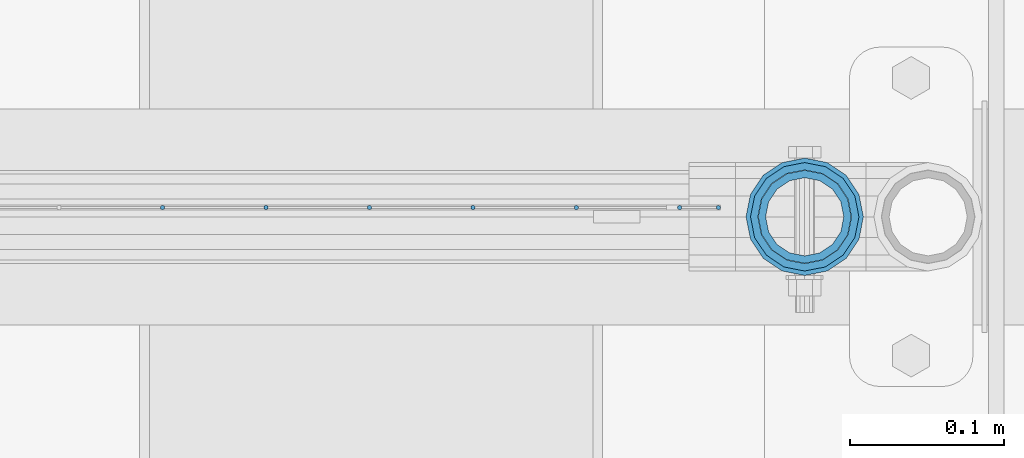
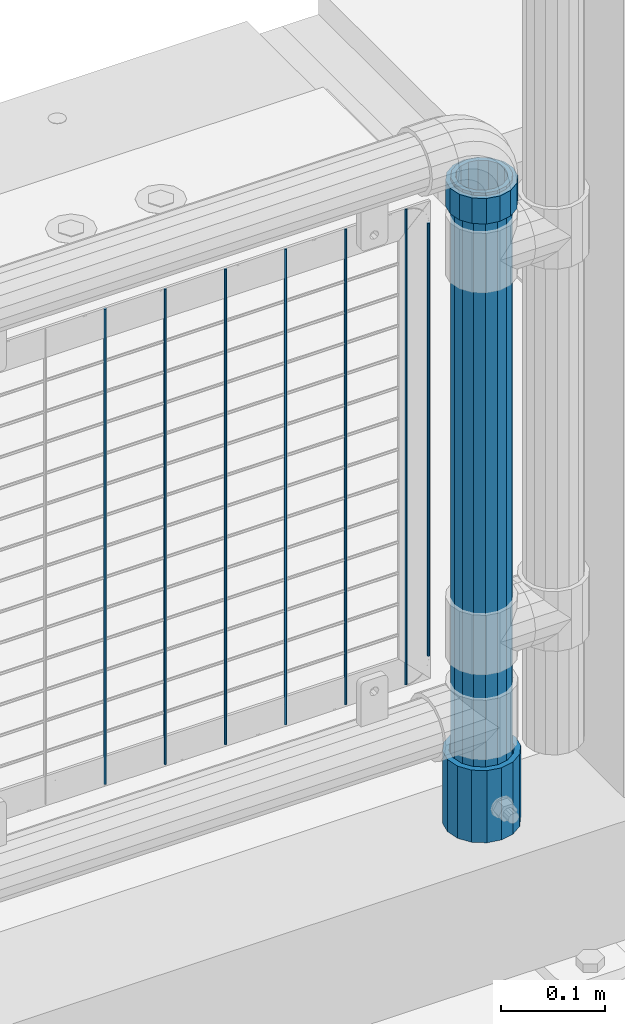
# One storey, part 93 of 219: 10 columns.
"""IFC2X3 building model written with IfcOpenShell, lengths in millimetres."""

from ifc_helpers import new_model, si_unit, frame, origin_with_axes, place, context, subcontext, project, spatial, faceted_brep, material, type_object, element, save


model = new_model("IFC2X3")

# Units and contexts
model_context = context("Model", 3, precision=1e-05, world=origin_with_axes())
body_context = subcontext(model_context, "Body", "Model", "MODEL_VIEW")
ifc_project = project(units=[si_unit("LENGTHUNIT", "METRE", prefix="MILLI"), si_unit("AREAUNIT", "SQUARE_METRE"), si_unit("VOLUMEUNIT", "CUBIC_METRE"), si_unit("MASSUNIT", "GRAM", prefix="KILO"), si_unit("TIMEUNIT", "SECOND"), si_unit("PLANEANGLEUNIT", "RADIAN"), si_unit("SOLIDANGLEUNIT", "STERADIAN"), si_unit("THERMODYNAMICTEMPERATUREUNIT", "DEGREE_CELSIUS"), si_unit("LUMINOUSINTENSITYUNIT", "LUMEN")], contexts=[model_context])

# Site, building, storey
site_placement = place(None, origin_with_axes())
site = spatial("IfcSite", under=ifc_project, at=site_placement, CompositionType="ELEMENT")
building_placement = place(site_placement, origin_with_axes())
building = spatial("IfcBuilding", under=site, at=building_placement, Name="Standard", CompositionType="ELEMENT")
storey_placement = place(building_placement, origin_with_axes())
storey = spatial("IfcBuildingStorey", under=building, at=storey_placement, Name="Undefined", CompositionType="ELEMENT", Elevation=0.0)

# Columns
ifc_material_1 = material(Name="Misc_Undefined")
column_type_1 = type_object("IfcColumnType", PredefinedType="NOTDEFINED")
column_1_placement = place(storey_placement, frame((13431.0, 31664.5, 894.85), z_axis=(1.0, 0.0, 0.0), x_axis=(0.0, 0.0, 1.0)))
element("IfcColumn", 1, at=column_1_placement, inside=storey, type_object=column_type_1, material=ifc_material_1, context=body_context, shape_type="Brep", body=[
    faceted_brep([(0.0, -30.3499999999985, 0.0), (0.0, -28.0397438117179, 11.6144421722802), (30.0, -28.0397438117179, 11.6144421722805), (30.0, -30.3499999999985, 0.0), (0.0, -21.46069080901, 21.4606908090118), (30.0, -21.46069080901, 21.4606908090117), (0.0, -11.614442172282, 28.0397438117179), (30.0, -11.614442172282, 28.0397438117176), (0.0, 0.0, 30.3500000000004), (30.0, 0.0, 30.35), (0.0, 11.614442172282, 28.0397438117179), (30.0, 11.614442172282, 28.0397438117176), (0.0, 21.46069080901, 21.4606908090118), (30.0, 21.46069080901, 21.4606908090117), (0.0, 28.0397438117179, 11.6144421722802), (30.0, 28.0397438117179, 11.6144421722805), (0.0, 30.3499999999985, 0.0), (30.0, 30.3499999999985, 0.0), (0.0, 28.0397438117179, -11.6144421722802), (30.0, 28.0397438117179, -11.6144421722805), (0.0, 21.46069080901, -21.4606908090118), (30.0, 21.46069080901, -21.4606908090117), (0.0, 11.614442172282, -28.0397438117179), (30.0, 11.614442172282, -28.0397438117176), (0.0, 0.0, -30.3500000000004), (30.0, 0.0, -30.35), (0.0, -11.614442172282, -28.0397438117179), (30.0, -11.614442172282, -28.0397438117176), (0.0, -21.46069080901, -21.4606908090118), (30.0, -21.46069080901, -21.4606908090117), (0.0, -28.0397438117179, -11.6144421722802), (30.0, -28.0397438117179, -11.6144421722805), (0.0, -35.1500000000015, 0.0), (0.0, -32.4743655677703, -13.4513226476338), (30.0, -32.4743655677703, -13.4513226476329), (30.0, -35.1500000000015, 0.0), (0.0, -24.8548033587067, -24.8548033587067), (30.0, -24.8548033587067, -24.8548033587072), (0.0, -13.4513226476338, -32.4743655677721), (30.0, -13.4513226476338, -32.4743655677718), (0.0, 0.0, -35.1500000000015), (30.0, 0.0, -35.15), (0.0, 13.4513226476338, -32.4743655677721), (30.0, 13.4513226476338, -32.4743655677718), (0.0, 24.8548033587067, -24.8548033587067), (30.0, 24.8548033587067, -24.8548033587072), (0.0, 32.4743655677703, -13.4513226476338), (30.0, 32.4743655677703, -13.4513226476329), (0.0, 35.1500000000015, 0.0), (30.0, 35.1500000000015, 0.0), (0.0, 32.4743655677703, 13.4513226476338), (30.0, 32.4743655677703, 13.4513226476329), (0.0, 24.8548033587067, 24.8548033587067), (30.0, 24.8548033587067, 24.8548033587072), (0.0, 13.4513226476338, 32.4743655677721), (30.0, 13.4513226476338, 32.4743655677718), (0.0, 0.0, 35.1500000000015), (30.0, 0.0, 35.15), (0.0, -13.4513226476338, 32.4743655677721), (30.0, -13.4513226476338, 32.4743655677718), (0.0, -24.8548033587067, 24.8548033587067), (30.0, -24.8548033587067, 24.8548033587072), (0.0, -32.4743655677703, 13.4513226476338), (30.0, -32.4743655677703, 13.4513226476329)], [[[0, 1, 2, 3]], [[1, 4, 5, 2]], [[4, 6, 7, 5]], [[6, 8, 9, 7]], [[8, 10, 11, 9]], [[10, 12, 13, 11]], [[12, 14, 15, 13]], [[14, 16, 17, 15]], [[16, 18, 19, 17]], [[18, 20, 21, 19]], [[20, 22, 23, 21]], [[22, 24, 25, 23]], [[24, 26, 27, 25]], [[26, 28, 29, 27]], [[28, 30, 31, 29]], [[30, 0, 3, 31]], [[32, 33, 34, 35]], [[33, 36, 37, 34]], [[36, 38, 39, 37]], [[38, 40, 41, 39]], [[40, 42, 43, 41]], [[42, 44, 45, 43]], [[44, 46, 47, 45]], [[46, 48, 49, 47]], [[48, 50, 51, 49]], [[50, 52, 53, 51]], [[52, 54, 55, 53]], [[54, 56, 57, 55]], [[56, 58, 59, 57]], [[58, 60, 61, 59]], [[60, 62, 63, 61]], [[62, 32, 35, 63]], [[37, 39, 41, 43, 45, 47, 49, 51, 53, 55, 57, 59, 61, 63, 35, 34], [5, 7, 9, 11, 13, 15, 17, 19, 21, 23, 25, 27, 29, 31, 3, 2]], [[62, 60, 58, 56, 54, 52, 50, 48, 46, 44, 42, 40, 38, 36, 33, 32], [30, 28, 26, 24, 22, 20, 18, 16, 14, 12, 10, 8, 6, 4, 1, 0]]]),
])
ifc_material_2 = material()
column_type_2 = type_object("IfcColumnType", PredefinedType="NOTDEFINED")
column_2_placement = place(storey_placement, frame((13431.0, 31664.5, 168.019999999998), z_axis=(-1.0, 0.0, 0.0), x_axis=(0.0, 0.0, 1.0)))
element("IfcColumn", 2, at=column_2_placement, inside=storey, type_object=column_type_2, material=ifc_material_2, context=body_context, shape_type="Brep", body=[
    faceted_brep([(0.0, -25.3499999999985, 0.0), (0.0, -23.4203461491597, 9.70102501045585), (760.0, -23.4203461491597, 9.70102501045585), (760.0, -25.3499999999985, 0.0), (0.0, -17.9251569030785, 17.9251569030785), (760.0, -17.9251569030785, 17.9251569030785), (0.0, -9.70102501045403, 23.4203461491616), (760.0, -9.70102501045403, 23.4203461491616), (0.0, 0.0, 25.3500000000004), (760.0, 0.0, 25.3500000000004), (0.0, 9.70102501045403, 23.4203461491616), (760.0, 9.70102501045403, 23.4203461491616), (0.0, 17.9251569030785, 17.9251569030785), (760.0, 17.9251569030785, 17.9251569030785), (0.0, 23.4203461491597, 9.70102501045585), (760.0, 23.4203461491597, 9.70102501045585), (0.0, 25.3499999999985, 0.0), (760.0, 25.3499999999985, 0.0), (0.0, 23.4203461491597, -9.70102501045585), (760.0, 23.4203461491597, -9.70102501045585), (0.0, 17.9251569030785, -17.9251569030785), (760.0, 17.9251569030785, -17.9251569030785), (0.0, 9.70102501045403, -23.4203461491616), (760.0, 9.70102501045403, -23.4203461491616), (0.0, 0.0, -25.3500000000004), (760.0, 0.0, -25.3500000000004), (0.0, -9.70102501045403, -23.4203461491616), (760.0, -9.70102501045403, -23.4203461491616), (0.0, -17.9251569030785, -17.9251569030785), (760.0, -17.9251569030785, -17.9251569030785), (0.0, -23.4203461491597, -9.70102501045585), (760.0, -23.4203461491597, -9.70102501045585), (0.0, -30.1500000000015, 0.0), (0.0, -27.8549679052157, -11.5379054858076), (760.0, -27.8549679052157, -11.5379054858076), (760.0, -30.1500000000015, 0.0), (0.0, -21.3192694527752, -21.3192694527752), (760.0, -21.3192694527752, -21.3192694527752), (0.0, -11.5379054858058, -27.8549679052157), (760.0, -11.5379054858058, -27.8549679052157), (0.0, 0.0, -30.1499999999996), (760.0, 0.0, -30.1499999999996), (0.0, 11.5379054858058, -27.8549679052157), (760.0, 11.5379054858058, -27.8549679052157), (0.0, 21.3192694527752, -21.3192694527752), (760.0, 21.3192694527752, -21.3192694527752), (0.0, 27.8549679052157, -11.5379054858076), (760.0, 27.8549679052157, -11.5379054858076), (0.0, 30.1500000000015, 0.0), (760.0, 30.1500000000015, 0.0), (0.0, 27.8549679052157, 11.5379054858076), (760.0, 27.8549679052157, 11.5379054858076), (0.0, 21.3192694527752, 21.3192694527752), (760.0, 21.3192694527752, 21.3192694527752), (0.0, 11.5379054858058, 27.8549679052157), (760.0, 11.5379054858058, 27.8549679052157), (0.0, 0.0, 30.1499999999996), (760.0, 0.0, 30.1499999999996), (0.0, -11.5379054858058, 27.8549679052157), (760.0, -11.5379054858058, 27.8549679052157), (0.0, -21.3192694527752, 21.3192694527752), (760.0, -21.3192694527752, 21.3192694527752), (0.0, -27.8549679052157, 11.5379054858076), (760.0, -27.8549679052157, 11.5379054858076)], [[[0, 1, 2, 3]], [[1, 4, 5, 2]], [[4, 6, 7, 5]], [[6, 8, 9, 7]], [[8, 10, 11, 9]], [[10, 12, 13, 11]], [[12, 14, 15, 13]], [[14, 16, 17, 15]], [[16, 18, 19, 17]], [[18, 20, 21, 19]], [[20, 22, 23, 21]], [[22, 24, 25, 23]], [[24, 26, 27, 25]], [[26, 28, 29, 27]], [[28, 30, 31, 29]], [[30, 0, 3, 31]], [[32, 33, 34, 35]], [[33, 36, 37, 34]], [[36, 38, 39, 37]], [[38, 40, 41, 39]], [[40, 42, 43, 41]], [[42, 44, 45, 43]], [[44, 46, 47, 45]], [[46, 48, 49, 47]], [[48, 50, 51, 49]], [[50, 52, 53, 51]], [[52, 54, 55, 53]], [[54, 56, 57, 55]], [[56, 58, 59, 57]], [[58, 60, 61, 59]], [[60, 62, 63, 61]], [[62, 32, 35, 63]], [[37, 39, 41, 43, 45, 47, 49, 51, 53, 55, 57, 59, 61, 63, 35, 34], [5, 7, 9, 11, 13, 15, 17, 19, 21, 23, 25, 27, 29, 31, 3, 2]], [[62, 60, 58, 56, 54, 52, 50, 48, 46, 44, 42, 40, 38, 36, 33, 32], [30, 28, 26, 24, 22, 20, 18, 16, 14, 12, 10, 8, 6, 4, 1, 0]]]),
])
column_type_3 = type_object("IfcColumnType", PredefinedType="NOTDEFINED")
column_3_placement = place(storey_placement, frame((13431.0, 31664.5, 168.019999999998), z_axis=(0.0, 1.0, 0.0), x_axis=(0.0, 0.0, 1.0)))
element("IfcColumn", 3, at=column_3_placement, inside=storey, type_object=column_type_3, material=ifc_material_2, context=body_context, shape_type="Brep", body=[
    faceted_brep([(0.0, -31.75, 0.0), (0.0, -29.3331751572332, 12.1501989775934), (85.0, -29.3331751572332, 12.1501989775934), (85.0, -31.75, 0.0), (0.0, -22.4506403026735, 22.4506403026717), (85.0, -22.4506403026735, 22.4506403026717), (0.0, -12.1501989775916, 29.3331751572332), (85.0, -12.1501989775916, 29.3331751572332), (0.0, 0.0, 31.75), (85.0, 0.0, 31.75), (0.0, 12.1501989775916, 29.3331751572332), (85.0, 12.1501989775916, 29.3331751572332), (0.0, 22.4506403026735, 22.4506403026717), (85.0, 22.4506403026735, 22.4506403026717), (0.0, 29.3331751572332, 12.1501989775934), (85.0, 29.3331751572332, 12.1501989775934), (0.0, 31.75, 0.0), (85.0, 31.75, 0.0), (0.0, 29.3331751572332, -12.1501989775934), (85.0, 29.3331751572332, -12.1501989775934), (0.0, 22.4506403026735, -22.4506403026717), (85.0, 22.4506403026735, -22.4506403026717), (0.0, 12.1501989775916, -29.3331751572332), (85.0, 12.1501989775916, -29.3331751572332), (0.0, 0.0, -31.75), (85.0, 0.0, -31.75), (0.0, -12.1501989775916, -29.3331751572332), (85.0, -12.1501989775916, -29.3331751572332), (0.0, -22.4506403026735, -22.4506403026717), (85.0, -22.4506403026735, -22.4506403026717), (0.0, -29.3331751572332, -12.1501989775934), (85.0, -29.3331751572332, -12.1501989775934), (0.0, -38.0499999999993, 0.0), (0.0, -35.1536162120537, -14.5611046014928), (85.0, -35.1536162120537, -14.5611046014928), (85.0, -38.0499999999993, 0.0), (0.0, -26.9054130241475, -26.9054130241493), (85.0, -26.9054130241475, -26.9054130241493), (0.0, -14.561104601491, -35.1536162120537), (85.0, -14.561104601491, -35.1536162120537), (0.0, 0.0, -38.0499999999993), (85.0, 0.0, -38.0499999999993), (0.0, 14.561104601491, -35.1536162120537), (85.0, 14.561104601491, -35.1536162120537), (0.0, 26.9054130241475, -26.9054130241493), (85.0, 26.9054130241475, -26.9054130241493), (0.0, 35.1536162120537, -14.5611046014928), (85.0, 35.1536162120537, -14.5611046014928), (0.0, 38.0499999999993, 0.0), (85.0, 38.0499999999993, 0.0), (0.0, 35.1536162120537, 14.5611046014928), (85.0, 35.1536162120537, 14.5611046014928), (0.0, 26.9054130241475, 26.9054130241493), (85.0, 26.9054130241475, 26.9054130241493), (0.0, 14.561104601491, 35.1536162120537), (85.0, 14.561104601491, 35.1536162120537), (0.0, 0.0, 38.0499999999993), (85.0, 0.0, 38.0499999999993), (0.0, -14.561104601491, 35.1536162120537), (85.0, -14.561104601491, 35.1536162120537), (0.0, -26.9054130241475, 26.9054130241493), (85.0, -26.9054130241475, 26.9054130241493), (0.0, -35.1536162120537, 14.5611046014928), (85.0, -35.1536162120537, 14.5611046014928)], [[[0, 1, 2, 3]], [[1, 4, 5, 2]], [[4, 6, 7, 5]], [[6, 8, 9, 7]], [[8, 10, 11, 9]], [[10, 12, 13, 11]], [[12, 14, 15, 13]], [[14, 16, 17, 15]], [[16, 18, 19, 17]], [[18, 20, 21, 19]], [[20, 22, 23, 21]], [[22, 24, 25, 23]], [[24, 26, 27, 25]], [[26, 28, 29, 27]], [[28, 30, 31, 29]], [[30, 0, 3, 31]], [[32, 33, 34, 35]], [[33, 36, 37, 34]], [[36, 38, 39, 37]], [[38, 40, 41, 39]], [[40, 42, 43, 41]], [[42, 44, 45, 43]], [[44, 46, 47, 45]], [[46, 48, 49, 47]], [[48, 50, 51, 49]], [[50, 52, 53, 51]], [[52, 54, 55, 53]], [[54, 56, 57, 55]], [[56, 58, 59, 57]], [[58, 60, 61, 59]], [[60, 62, 63, 61]], [[62, 32, 35, 63]], [[37, 39, 41, 43, 45, 47, 49, 51, 53, 55, 57, 59, 61, 63, 35, 34], [5, 7, 9, 11, 13, 15, 17, 19, 21, 23, 25, 27, 29, 31, 3, 2]], [[62, 60, 58, 56, 54, 52, 50, 48, 46, 44, 42, 40, 38, 36, 33, 32], [30, 28, 26, 24, 22, 20, 18, 16, 14, 12, 10, 8, 6, 4, 1, 0]]]),
])
column_type_4 = type_object("IfcColumnType", Name="D3", PredefinedType="NOTDEFINED")
for number, where, z_axis, x_axis in (
    (4, (13350.0020000002, 31670.4997841009, 353.02), (-1.0, 0.0, 0.0), (0.0, 0.0, 1.0)),
    (5, (13282.9740000002, 31670.4997983097, 353.02), (-1.0, 0.0, 0.0), (0.0, 0.0, 1.0)),
    (6, (13215.9460000002, 31670.4998125185, 353.02), (-1.0, 0.0, 0.0), (0.0, 0.0, 1.0)),
    (7, (13148.9180000002, 31670.4998267273, 353.02), (-1.0, 0.0, 0.0), (0.0, 0.0, 1.0)),
    (8, (13081.8900000001, 31670.4998409362, 353.02), (-1.0, 0.0, 0.0), (0.0, 0.0, 1.0)),
    (9, (13014.8620000001, 31670.499855145, 353.02), (-1.0, 0.0, 0.0), (0.0, 0.0, 1.0)),
):
    element("IfcColumn", number, at=place(storey_placement, frame(where, z_axis=z_axis, x_axis=x_axis)), inside=storey, type_object=column_type_4, material=ifc_material_1, ObjectType="D3", context=body_context, shape_type="Brep", body=[
        faceted_brep([(0.0, -1.5, -5.6843418860808e-14), (0.0, -0.75, -1.29903810567669), (560.0, -0.75, -1.29903810567703), (560.0, -1.5, 0.0), (0.0, 0.75, -1.29903810567669), (560.0, 0.75, -1.29903810567703), (0.0, 1.5, -5.6843418860808e-14), (560.0, 1.5, 0.0), (0.0, 0.75, 1.29903810567669), (560.0, 0.75, 1.29903810567703), (0.0, -0.75, 1.29903810567669), (560.0, -0.75, 1.29903810567703)], [[[0, 1, 2, 3]], [[1, 4, 5, 2]], [[4, 6, 7, 5]], [[6, 8, 9, 7]], [[8, 10, 11, 9]], [[10, 0, 3, 11]], [[5, 7, 9, 11, 3, 2]], [[10, 8, 6, 4, 1, 0]]]),
    ])
column_4_placement = place(storey_placement, frame((13375.0000000001, 31670.4997788013, 378.02), z_axis=(-1.0, 0.0, 0.0), x_axis=(0.0, 0.0, 1.0)))
element("IfcColumn", 10, at=column_4_placement, inside=storey, type_object=column_type_4, material=ifc_material_1, ObjectType="D3", context=body_context, shape_type="Brep", body=[
    faceted_brep([(0.0, -1.5, -5.6843418860808e-14), (0.0, -0.75, -1.29903810567669), (510.0, -0.75, -1.29903810567703), (510.0, -1.5, 0.0), (0.0, 0.75, -1.29903810567669), (510.0, 0.75, -1.29903810567703), (0.0, 1.5, -5.6843418860808e-14), (510.0, 1.5, 0.0), (0.0, 0.75, 1.29903810567669), (510.0, 0.75, 1.29903810567703), (0.0, -0.75, 1.29903810567669), (510.0, -0.75, 1.29903810567703)], [[[0, 1, 2, 3]], [[1, 4, 5, 2]], [[4, 6, 7, 5]], [[6, 8, 9, 7]], [[8, 10, 11, 9]], [[10, 0, 3, 11]], [[5, 7, 9, 11, 3, 2]], [[10, 8, 6, 4, 1, 0]]]),
])

save(model, "model.ifc")
